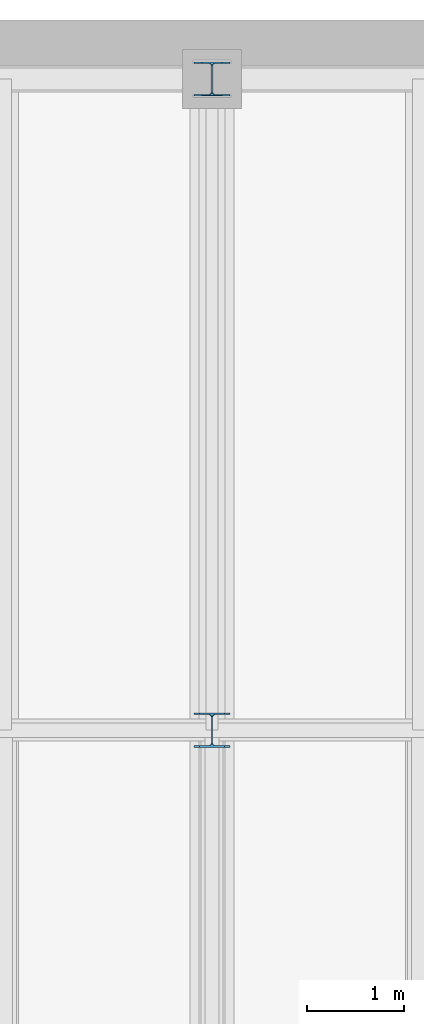
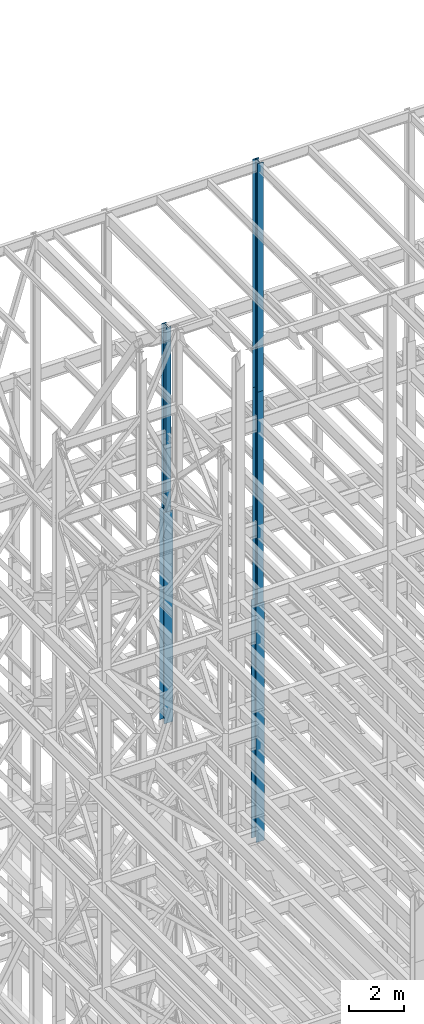
# One storey, part 58 of 150: 5 columns.
"""IFC2X3 building model written with IfcOpenShell, lengths in millimetres."""

from ifc_helpers import new_model, si_unit, frame, origin_with_axes, origin_2d_with_axis, place, context, subcontext, project, spatial, i_section, extrude, material, type_object, element, save


model = new_model("IFC2X3")

# Units and contexts
model_context = context("Model", 3, precision=1e-05, world=origin_with_axes())
body_context = subcontext(model_context, "Body", "Model", "MODEL_VIEW")
ifc_project = project(units=[si_unit("LENGTHUNIT", "METRE", prefix="MILLI"), si_unit("AREAUNIT", "SQUARE_METRE"), si_unit("VOLUMEUNIT", "CUBIC_METRE"), si_unit("MASSUNIT", "GRAM", prefix="KILO"), si_unit("TIMEUNIT", "SECOND"), si_unit("PLANEANGLEUNIT", "RADIAN"), si_unit("SOLIDANGLEUNIT", "STERADIAN"), si_unit("THERMODYNAMICTEMPERATUREUNIT", "DEGREE_CELSIUS"), si_unit("LUMINOUSINTENSITYUNIT", "LUMEN")], contexts=[model_context])

# Site, building, storey
site_placement = place(None, origin_with_axes())
site = spatial("IfcSite", under=ifc_project, at=site_placement, CompositionType="ELEMENT")
building_placement = place(site_placement, origin_with_axes())
building = spatial("IfcBuilding", under=site, at=building_placement, Name="Undefined", CompositionType="ELEMENT")
storey_placement = place(building_placement, origin_with_axes())
storey = spatial("IfcBuildingStorey", under=building, at=storey_placement, Name="Undefined", CompositionType="ELEMENT", Elevation=0.0)

# Columns
ifc_material = material(Name="STEEL/A992")
column_type_1 = type_object("IfcColumnType", Name="W14X43", PredefinedType="NOTDEFINED")
column_1_placement = place(storey_placement, frame((18186.4, 38862.0, 46253.4), z_axis=(0.0, 0.0, 1.0), x_axis=(1.0, 0.0, 0.0)))
element("IfcColumn", 1, at=column_1_placement, inside=storey, type_object=column_type_1, material=ifc_material, Name="COLUMN", ObjectType="W14X43", context=body_context, shape_type="SweptSolid", body=[
    extrude(i_section(OverallWidth=203.2, OverallDepth=346.075, WebThickness=7.9375, FlangeThickness=13.462, FilletRadius=21.4629, at=origin_2d_with_axis()), frame((0.0, 0.0, 8229.60000000002), z_axis=(0.0, 0.0, -1.0), x_axis=(-1.0, 0.0, 0.0)), (0.0, 0.0, 1.0), 8229.60000000001),
])
column_type_2 = type_object("IfcColumnType", Name="W14X90", PredefinedType="NOTDEFINED")
column_2_placement = place(storey_placement, frame((18186.4, 38862.0, 36804.6012877801), z_axis=(0.0, 0.0, 1.0), x_axis=(1.0, 0.0, 0.0)))
element("IfcColumn", 2, at=column_2_placement, inside=storey, type_object=column_type_2, material=ifc_material, Name="COLUMN", ObjectType="W14X90", context=body_context, shape_type="SweptSolid", body=[
    extrude(i_section(OverallWidth=368.3, OverallDepth=355.6, WebThickness=11.1125, FlangeThickness=18.034, FilletRadius=32.7659, at=origin_2d_with_axis()), frame((0.0, 0.0, 9448.79776734), z_axis=(0.0, 0.0, -1.0), x_axis=(-1.0, 0.0, 0.0)), (0.0, 0.0, 1.0), 9448.79776733999),
])
column_3_placement = place(storey_placement, frame((18186.4, 32131.0, 35585.4), z_axis=(0.0, 0.0, 1.0), x_axis=(1.0, 0.0, 0.0)))
element("IfcColumn", 3, at=column_3_placement, inside=storey, type_object=column_type_2, material=ifc_material, Name="COLUMN", ObjectType="W14X90", context=body_context, shape_type="SweptSolid", body=[
    extrude(i_section(OverallWidth=368.3, OverallDepth=355.6, WebThickness=11.1125, FlangeThickness=18.034, FilletRadius=32.7659, at=origin_2d_with_axis()), frame((0.0, 0.0, 10668.0009448801), z_axis=(0.0, 0.0, -1.0), x_axis=(-1.0, 0.0, 0.0)), (0.0, 0.0, 1.0), 10668.0009448801),
])
column_type_3 = type_object("IfcColumnType", Name="W14X74", PredefinedType="NOTDEFINED")
column_4_placement = place(storey_placement, frame((18186.4, 32131.0, 55702.2), z_axis=(0.0, 0.0, 1.0), x_axis=(1.0, 0.0, 0.0)))
element("IfcColumn", 4, at=column_4_placement, inside=storey, type_object=column_type_3, material=ifc_material, Name="COLUMN", ObjectType="W14X74", context=body_context, shape_type="SweptSolid", body=[
    extrude(i_section(OverallWidth=256.54, OverallDepth=358.775, WebThickness=11.1125, FlangeThickness=19.939, FilletRadius=21.336, at=origin_2d_with_axis()), frame((0.0, 0.0, 10210.8), z_axis=(0.0, 0.0, -1.0), x_axis=(-1.0, 0.0, 0.0)), (0.0, 0.0, 1.0), 10210.8),
])
column_5_placement = place(storey_placement, frame((18186.4, 32131.0, 46253.4009448801), z_axis=(0.0, 0.0, 1.0), x_axis=(1.0, 0.0, 0.0)))
element("IfcColumn", 5, at=column_5_placement, inside=storey, type_object=column_type_3, material=ifc_material, Name="COLUMN", ObjectType="W14X74", context=body_context, shape_type="SweptSolid", body=[
    extrude(i_section(OverallWidth=256.54, OverallDepth=358.775, WebThickness=11.1125, FlangeThickness=19.939, FilletRadius=21.336, at=origin_2d_with_axis()), frame((0.0, 0.0, 9448.79905511992), z_axis=(0.0, 0.0, -1.0), x_axis=(-1.0, 0.0, 0.0)), (0.0, 0.0, 1.0), 9448.79905511991),
])

save(model, "model.ifc")
